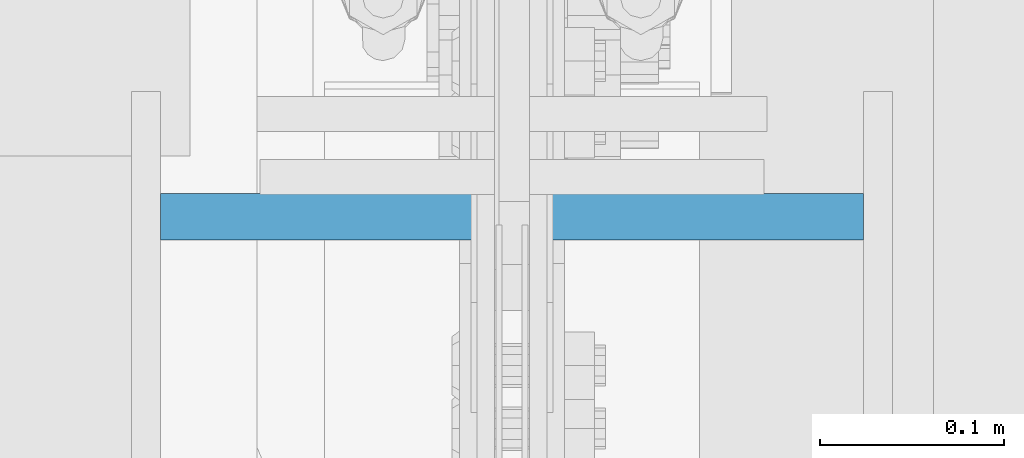
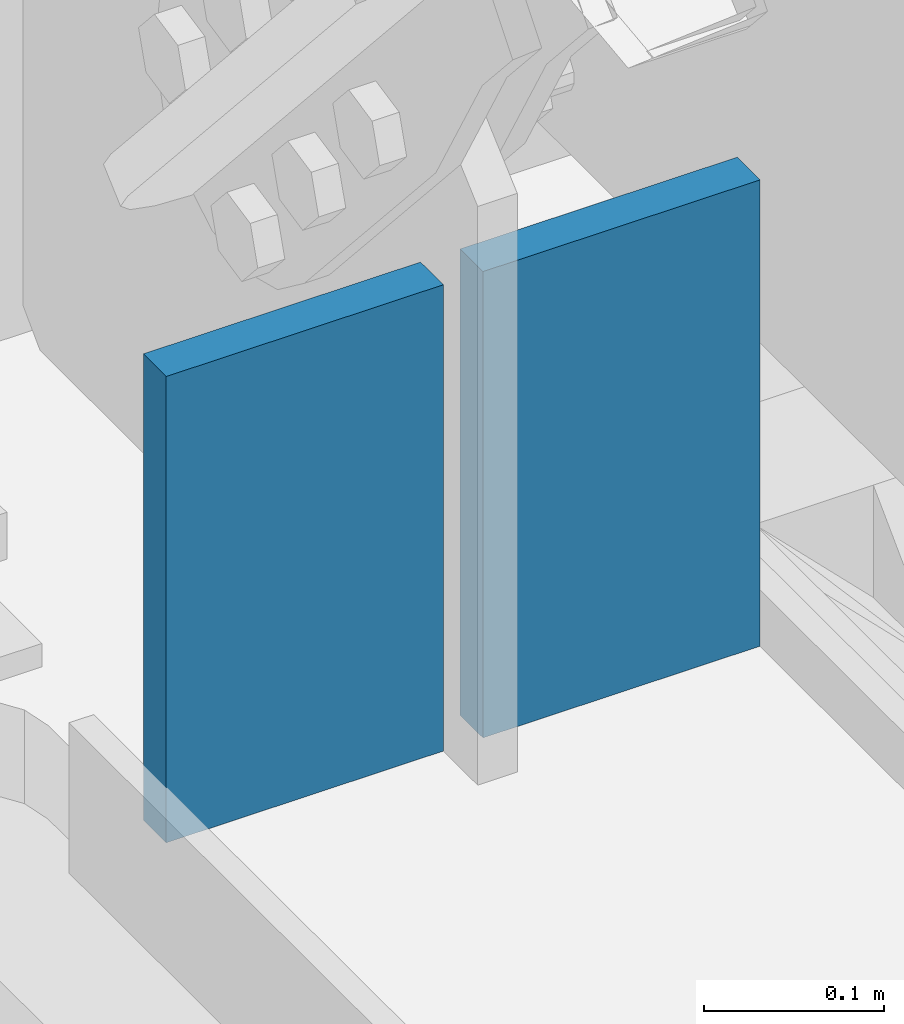
# One storey, part 557 of 1179: 2 columns, 2 elements without a shape of their own.
"""IFC2X3 building model written with IfcOpenShell, lengths in millimetres."""

import ifcopenshell
import ifcopenshell.guid

model = None  # the IFC model being written
_history = None  # IfcOwnerHistory: only IFC2X3 demands one
_inside = {}  # id of a spatial element -> (the spatial element, [elements in it])
_under = {}  # id of a project, library or spatial element -> (it, [spatial elements below it])
_declared = {}  # id of a project -> (the project, [libraries it declares])
_typed = {}  # id of a type object -> (the type object, [elements of that type])
_made_of = {}  # id of a material, layer set ... -> (it, [elements and type objects made of it])


def new_model(schema):
    """Start an empty IFC model of exactly this schema.

    Asked for "IFC4X3", IfcOpenShell would pick the latest addendum, in which some entities
    have other attributes; the version numbers below select the first issue.
    IFC2X3 requires an IfcOwnerHistory on every rooted entity: one is made here for all.
    """
    global model, _history
    if schema == "IFC4X3":
        model = ifcopenshell.file(schema_version=(4, 3, 0, 0))
    else:
        model = ifcopenshell.file(schema=schema)
    _inside.clear()
    _under.clear()
    _declared.clear()
    _typed.clear()
    _made_of.clear()
    _history = None
    if model.schema == "IFC2X3":
        org = make("IfcOrganization", Name="unknown")
        user = make(
            "IfcPersonAndOrganization",
            ThePerson=make("IfcPerson", FamilyName="unknown"),
            TheOrganization=org,
        )
        app = make(
            "IfcApplication",
            ApplicationDeveloper=org,
            Version="unknown",
            ApplicationFullName="unknown",
            ApplicationIdentifier="unknown",
        )
        _history = make(
            "IfcOwnerHistory",
            OwningUser=user,
            OwningApplication=app,
            ChangeAction="ADDED",
            CreationDate=0,
        )
    return model


def make(cls, **values):
    """One entity of the class cls with the attributes given. An attribute that is None is left unset."""
    return model.create_entity(
        cls, **{name: value for name, value in values.items() if value is not None}
    )


def rooted(cls, **values):
    """An entity with a GlobalId (a new one), such as an element, a storey or a relation."""
    return make(cls, GlobalId=ifcopenshell.guid.new(), OwnerHistory=_history, **values)


def si_unit(unit_type, name, prefix=None):
    """IfcSIUnit, for example si_unit("LENGTHUNIT", "METRE", prefix="MILLI")."""
    return make("IfcSIUnit", UnitType=unit_type, Prefix=prefix, Name=name)


def assignment(units):
    """IfcUnitAssignment: the units of a project."""
    return None if units is None else make("IfcUnitAssignment", Units=units)


def point(xyz):
    """IfcCartesianPoint."""
    return None if xyz is None else make("IfcCartesianPoint", Coordinates=xyz)


def direction(xyz):
    """IfcDirection."""
    return None if xyz is None else make("IfcDirection", DirectionRatios=xyz)


def frame(location, z_axis=None, x_axis=None):
    """IfcAxis2Placement3D, a coordinate frame: its origin and axes. An axis left out is left unset."""
    return make(
        "IfcAxis2Placement3D",
        Location=point(location),
        Axis=direction(z_axis),
        RefDirection=direction(x_axis),
    )


def origin_with_axes():
    """The frame at (0, 0, 0) with the z axis (0, 0, 1) and the x axis (1, 0, 0) written out."""
    return frame((0.0, 0.0, 0.0), z_axis=(0.0, 0.0, 1.0), x_axis=(1.0, 0.0, 0.0))


def place(relative_to, where):
    """IfcLocalPlacement: puts the frame where relative to a parent placement (None: the world)."""
    return make(
        "IfcLocalPlacement", PlacementRelTo=relative_to, RelativePlacement=where
    )


def context(
    kind, dimensions, precision=None, world=None, true_north=None, identifier=None
):
    """IfcGeometricRepresentationContext, for example the 3D "Model" context."""
    return make(
        "IfcGeometricRepresentationContext",
        ContextIdentifier=identifier,
        ContextType=kind,
        CoordinateSpaceDimension=dimensions,
        Precision=precision,
        WorldCoordinateSystem=world,
        TrueNorth=true_north,
    )


def subcontext(parent, identifier, kind, view, scale=None):
    """IfcGeometricRepresentationSubContext, for example "Body" below "Model"."""
    return make(
        "IfcGeometricRepresentationSubContext",
        ContextIdentifier=identifier,
        ContextType=kind,
        ParentContext=parent,
        TargetScale=scale,
        TargetView=view,
    )


def project(units=None, contexts=None):
    """IfcProject with its units and contexts."""
    return rooted(
        "IfcProject",
        Name="project",
        RepresentationContexts=contexts,
        UnitsInContext=assignment(units),
    )


def spatial(cls, under=None, at=None, **own):
    """A site, building, storey or space (cls), placed at a placement, below another one or the project."""
    s = rooted(cls, ObjectPlacement=at, **own)
    if under is not None:
        _under.setdefault(under.id(), (under, []))[1].append(s)
    return s


def faces_of(points, faces, orient=None, outer=None):
    """IfcFace entities. A face is a list of loops; a loop is a list of indices into points, from 0.

    orient and outer hold one flag for each loop. By default every Orientation is true, the
    first loop of a face is its IfcFaceOuterBound and the others are IfcFaceBound.
    """
    made = []
    for i, loops in enumerate(faces):
        bounds = []
        for j, loop in enumerate(loops):
            is_outer = j == 0 if outer is None else outer[i][j]
            bounds.append(
                make(
                    "IfcFaceOuterBound" if is_outer else "IfcFaceBound",
                    Bound=make("IfcPolyLoop", Polygon=[points[k] for k in loop]),
                    Orientation=True if orient is None else orient[i][j],
                )
            )
        made.append(make("IfcFace", Bounds=bounds))
    return made


def faceted_brep(points, faces, orient=None, outer=None, voids=None):
    """IfcFacetedBrep: a solid bounded by flat faces; with voids (closed shells), ...WithVoids."""
    shared = [point(p) for p in points]
    hull = make("IfcClosedShell", CfsFaces=faces_of(shared, faces, orient, outer))
    if voids is None:
        return make("IfcFacetedBrep", Outer=hull)
    return make(
        "IfcFacetedBrepWithVoids",
        Outer=hull,
        Voids=[
            make(cls, CfsFaces=faces_of(shared, fs, o, b)) for cls, fs, o, b in voids
        ],
    )


def shape(context_of_items, identifier, shape_type, items):
    """IfcShapeRepresentation: the items that make up one representation, for example the "Body"."""
    return make(
        "IfcShapeRepresentation",
        ContextOfItems=context_of_items,
        RepresentationIdentifier=identifier,
        RepresentationType=shape_type,
        Items=items,
    )


def material(Name=None, Category=None):
    """IfcMaterial."""
    return make("IfcMaterial", Name=Name, Category=Category)


def made_of(thing, what):
    """Note that an element or type object is made of a material, layer set ...; save() writes the relation."""
    if what is not None:
        _made_of.setdefault(what.id(), (what, []))[1].append(thing)
    return thing


def type_object(cls, material=None, **own):
    """A type object (cls), such as IfcWallType, which elements share."""
    return made_of(rooted(cls, **own), material)


def element(
    cls,
    number,
    at=None,
    inside=None,
    cuts=None,
    type_object=None,
    material=None,
    context=None,
    identifier="Body",
    shape_type=None,
    held_by="IfcProductDefinitionShape",
    body=None,
    shapes=None,
    **own,
):
    """One element of the class cls, such as IfcWall. Its Tag is "e" and its number.

    at: its placement. inside: the storey or other place that contains it. cuts: it is an
    opening in that element (IfcRelVoidsElement). A single representation is given by context,
    identifier, shape_type and body (its items); several are given by shapes. held_by: the class
    of the entity that holds the representations. save() writes the other relations.
    """
    e = rooted(cls, Tag="e%d" % number, ObjectPlacement=at, **own)
    if body is not None:
        shapes = [shape(context, identifier, shape_type, body)]
    if shapes is not None:
        e.Representation = make(held_by, Representations=shapes)
    if inside is not None:
        _inside.setdefault(inside.id(), (inside, []))[1].append(e)
    if cuts is not None:
        rooted(
            "IfcRelVoidsElement", RelatingBuildingElement=cuts, RelatedOpeningElement=e
        )
    if type_object is not None:
        _typed.setdefault(type_object.id(), (type_object, []))[1].append(e)
    return made_of(e, material)


def aggregate(whole, parts):
    """IfcRelAggregates: a whole, such as a stair, and the parts it consists of."""
    return rooted("IfcRelAggregates", RelatingObject=whole, RelatedObjects=parts)


def save(model, path):
    """Write the relations noted so far, then the file.

    IfcRelAggregates (storeys below a building ...), IfcRelContainedInSpatialStructure (elements
    in a storey), IfcRelDefinesByType, IfcRelAssociatesMaterial and IfcRelDeclares: one each for
    every whole, place, type object, material and project.
    """
    for whole, parts in _under.values():
        aggregate(whole, parts)
    for where, things in _inside.values():
        rooted(
            "IfcRelContainedInSpatialStructure",
            RelatedElements=things,
            RelatingStructure=where,
        )
    for kind, things in _typed.values():
        rooted("IfcRelDefinesByType", RelatedObjects=things, RelatingType=kind)
    for what, things in _made_of.values():
        rooted("IfcRelAssociatesMaterial", RelatedObjects=things, RelatingMaterial=what)
    for by, libraries in _declared.values():
        rooted("IfcRelDeclares", RelatingContext=by, RelatedDefinitions=libraries)
    model.write(path)


model = new_model("IFC2X3")

# Units and contexts
model_context = context("Model", 3, precision=1e-05, world=origin_with_axes())
body_context = subcontext(model_context, "Body", "Model", "MODEL_VIEW")
ifc_project = project(units=[si_unit("LENGTHUNIT", "METRE", prefix="MILLI"), si_unit("AREAUNIT", "SQUARE_METRE"), si_unit("VOLUMEUNIT", "CUBIC_METRE"), si_unit("MASSUNIT", "GRAM", prefix="KILO"), si_unit("TIMEUNIT", "SECOND"), si_unit("PLANEANGLEUNIT", "RADIAN"), si_unit("SOLIDANGLEUNIT", "STERADIAN"), si_unit("THERMODYNAMICTEMPERATUREUNIT", "DEGREE_CELSIUS"), si_unit("LUMINOUSINTENSITYUNIT", "LUMEN")], contexts=[model_context])

# Site, building, storey
site_placement = place(None, origin_with_axes())
site = spatial("IfcSite", under=ifc_project, at=site_placement, CompositionType="ELEMENT")
building_placement = place(site_placement, origin_with_axes())
building = spatial("IfcBuilding", under=site, at=building_placement, Name="Undefined", CompositionType="ELEMENT")
storey_placement = place(building_placement, origin_with_axes())
storey = spatial("IfcBuildingStorey", under=building, at=storey_placement, Name="Undefined", CompositionType="ELEMENT", Elevation=0.0)

# Assembly, column
assembly_1_placement = place(storey_placement, origin_with_axes())
assembly_1 = element("IfcElementAssembly", 1, at=assembly_1_placement, inside=storey, Name="PLATE", AssemblyPlace="NOTDEFINED", PredefinedType="RIGID_FRAME")
ifc_material = material(Name="STEEL/A572-GR.50")
column_type = type_object("IfcColumnType", PredefinedType="NOTDEFINED")
column_1_placement = place(assembly_1_placement, frame((24206.2, 33930.0068835736, -215.9), z_axis=(1.0, 0.0, 0.0), x_axis=(0.0, 0.0, 1.0)))
column_1 = element("IfcColumn", 2, at=column_1_placement, type_object=column_type, material=ifc_material, Name="PLATE", context=body_context, shape_type="Brep", body=[
    faceted_brep([(0.0, 12.6999999999998, -88.9000000000015), (0.0, 12.6999999999998, 88.9000000000015), (316.265334197486, 12.6999999999971, 88.9000000000015), (316.265334197486, 12.6999999999971, -88.9000000000015), (0.0, -12.6999999999998, 88.9000000000015), (316.265334197486, -12.6999999999971, 88.9000000000015), (0.0, -12.6999999999998, -88.9000000000015), (316.265334197486, -12.6999999999971, -88.9000000000015)], [[[0, 1, 2, 3]], [[1, 4, 5, 2]], [[4, 6, 7, 5]], [[6, 0, 3, 7]], [[5, 7, 3, 2]], [[6, 4, 1, 0]]]),
])
aggregate(assembly_1, [column_1])

assembly_2_placement = place(storey_placement, origin_with_axes())
assembly_2 = element("IfcElementAssembly", 3, at=assembly_2_placement, inside=storey, Name="PLATE", AssemblyPlace="NOTDEFINED", PredefinedType="RIGID_FRAME")
column_2_placement = place(assembly_2_placement, frame((24409.4, 33930.0068835736, -215.9), z_axis=(-1.0, 0.0, 0.0), x_axis=(0.0, 0.0, 1.0)))
column_2 = element("IfcColumn", 4, at=column_2_placement, type_object=column_type, material=ifc_material, Name="PLATE", context=body_context, shape_type="Brep", body=[
    faceted_brep([(0.0, 12.6999999999998, -88.9000000000015), (0.0, 12.6999999999998, 88.9000000000015), (316.265334197486, 12.6999999999971, 88.9000000000015), (316.265334197486, 12.6999999999971, -88.9000000000015), (0.0, -12.6999999999998, 88.9000000000015), (316.265334197486, -12.6999999999971, 88.9000000000015), (0.0, -12.6999999999998, -88.9000000000015), (316.265334197486, -12.6999999999971, -88.9000000000015)], [[[0, 1, 2, 3]], [[1, 4, 5, 2]], [[4, 6, 7, 5]], [[6, 0, 3, 7]], [[5, 7, 3, 2]], [[6, 4, 1, 0]]]),
])
aggregate(assembly_2, [column_2])

save(model, "model.ifc")
